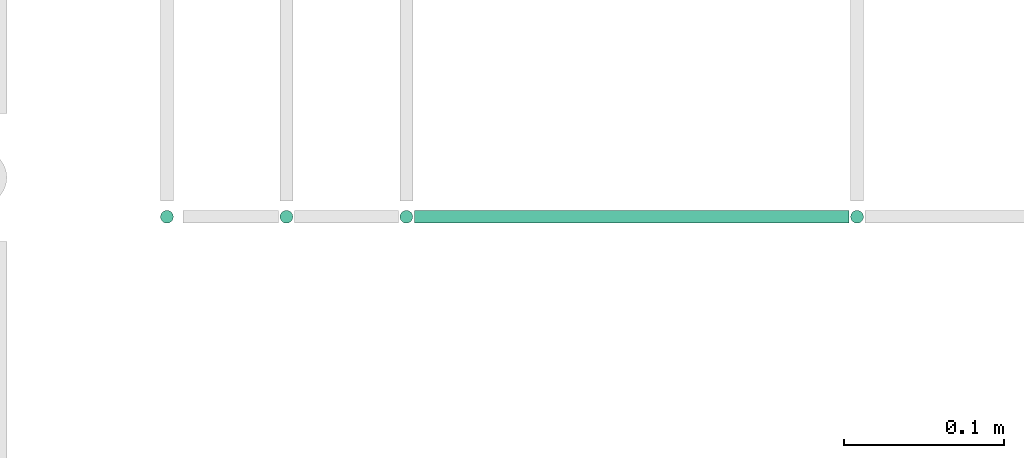
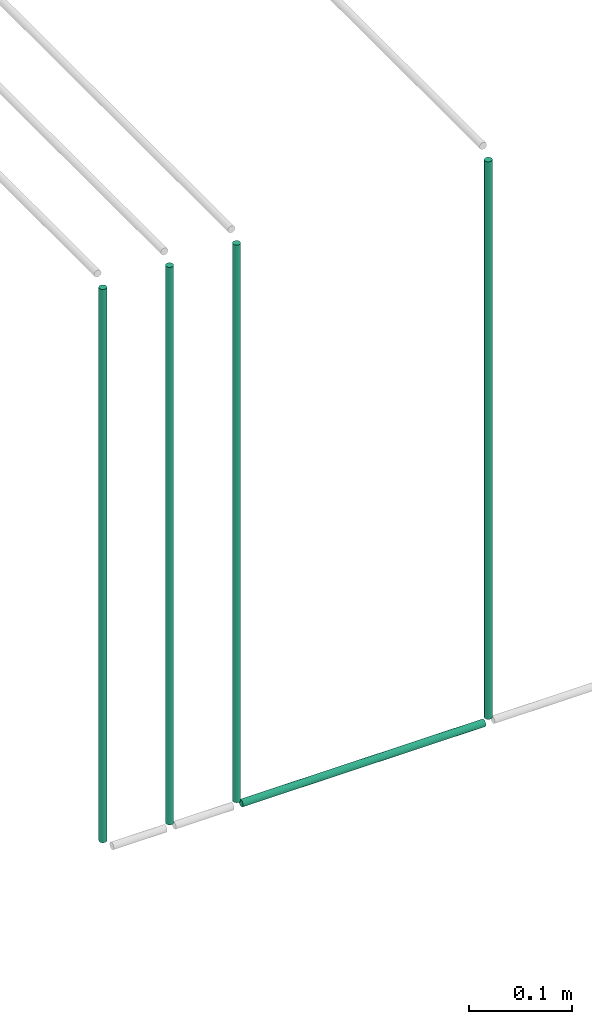
# One storey, part 243 of 331: 5 flow segments.
"""IFC2X3 building model written with IfcOpenShell, lengths in millimetres."""

from ifc_helpers import new_model, entity, si_unit, converted_unit, derived_unit, direction, frame, origin, origin_2d_with_axis, place, context, subcontext, project, spatial, circle, extrude, type_object, element, save


model = new_model("IFC2X3")

# Units and contexts
model_context = context("Model", 3, precision=0.01, world=origin(), true_north=direction((6.12303176911189e-17, 1.0)))
body_context = subcontext(model_context, "Body", "Model", "MODEL_VIEW")
ifc_project = project(units=[si_unit("LENGTHUNIT", "METRE", prefix="MILLI"), si_unit("AREAUNIT", "SQUARE_METRE"), si_unit("VOLUMEUNIT", "CUBIC_METRE"), converted_unit("PLANEANGLEUNIT", "DEGREE", entity("IfcRatioMeasure", 0.0174532925199433), si_unit("PLANEANGLEUNIT", "RADIAN"), dimensions=[0, 0, 0, 0, 0, 0, 0]), si_unit("MASSUNIT", "GRAM", prefix="KILO"), derived_unit("MASSDENSITYUNIT", [(si_unit("MASSUNIT", "GRAM", prefix="KILO"), 1), (si_unit("LENGTHUNIT", "METRE"), -3)]), derived_unit("MOMENTOFINERTIAUNIT", [(si_unit("LENGTHUNIT", "METRE"), 4)]), si_unit("TIMEUNIT", "SECOND"), si_unit("FREQUENCYUNIT", "HERTZ"), si_unit("THERMODYNAMICTEMPERATUREUNIT", "DEGREE_CELSIUS"), derived_unit("THERMALTRANSMITTANCEUNIT", [(si_unit("MASSUNIT", "GRAM", prefix="KILO"), 1), (si_unit("THERMODYNAMICTEMPERATUREUNIT", "KELVIN"), -1), (si_unit("TIMEUNIT", "SECOND"), -3)]), derived_unit("VOLUMETRICFLOWRATEUNIT", [(si_unit("LENGTHUNIT", "METRE"), 3), (si_unit("TIMEUNIT", "SECOND"), -1)]), derived_unit("MASSFLOWRATEUNIT", [(si_unit("MASSUNIT", "GRAM", prefix="KILO"), 1), (si_unit("TIMEUNIT", "SECOND"), -1)]), derived_unit("ROTATIONALFREQUENCYUNIT", [(si_unit("TIMEUNIT", "SECOND"), -1)]), si_unit("ELECTRICCURRENTUNIT", "AMPERE"), si_unit("ELECTRICVOLTAGEUNIT", "VOLT"), si_unit("POWERUNIT", "WATT"), si_unit("FORCEUNIT", "NEWTON", prefix="KILO"), si_unit("ILLUMINANCEUNIT", "LUX"), si_unit("LUMINOUSFLUXUNIT", "LUMEN"), si_unit("LUMINOUSINTENSITYUNIT", "CANDELA"), derived_unit("USERDEFINED", [(si_unit("MASSUNIT", "GRAM", prefix="KILO"), -1), (si_unit("LENGTHUNIT", "METRE"), -2), (si_unit("TIMEUNIT", "SECOND"), 3), (si_unit("LUMINOUSFLUXUNIT", "LUMEN"), 1)]), derived_unit("LINEARVELOCITYUNIT", [(si_unit("LENGTHUNIT", "METRE"), 1), (si_unit("TIMEUNIT", "SECOND"), -1)]), si_unit("PRESSUREUNIT", "PASCAL"), derived_unit("USERDEFINED", [(si_unit("LENGTHUNIT", "METRE"), -2), (si_unit("MASSUNIT", "GRAM", prefix="KILO"), 1), (si_unit("TIMEUNIT", "SECOND"), -2)]), derived_unit("LINEARFORCEUNIT", [(si_unit("MASSUNIT", "GRAM", prefix="KILO"), 1), (si_unit("LENGTHUNIT", "METRE"), 1), (si_unit("TIMEUNIT", "SECOND"), -2), (si_unit("LENGTHUNIT", "METRE"), -1)]), derived_unit("PLANARFORCEUNIT", [(si_unit("MASSUNIT", "GRAM", prefix="KILO"), 1), (si_unit("LENGTHUNIT", "METRE"), 1), (si_unit("TIMEUNIT", "SECOND"), -2), (si_unit("LENGTHUNIT", "METRE"), -2)])], contexts=[model_context])

# Site, building, storey
site_placement = place(None, frame((0.0, -0.00077364408347762, 0.0)))
site = spatial("IfcSite", under=ifc_project, at=site_placement, CompositionType="ELEMENT")
building_placement = place(site_placement, origin())
building = spatial("IfcBuilding", under=site, at=building_placement, CompositionType="ELEMENT")
storey_placement = place(building_placement, origin())
storey = spatial("IfcBuildingStorey", under=building, at=storey_placement, CompositionType="ELEMENT", Elevation=0.0)

# Flow segments
pipe_segment_type = type_object("IfcPipeSegmentType", PredefinedType="NOTDEFINED")
for number, where in (
    (1, (60309.3854351487, 16292.9115686369, 6680.0)),
    (2, (60027.5518978448, 16292.9115686369, 6680.0)),
):
    element("IfcFlowSegment", number, at=place(building_placement, frame(where)), inside=storey, type_object=pipe_segment_type, context=body_context, shape_type="SweptSolid", body=[
        extrude(circle(Radius=4.0, at=origin_2d_with_axis()), frame((5.59527223591499, 5.59527223591499, 0.0), z_axis=(0.0, 0.0, 1.0), x_axis=(-1.0, 0.0, 0.0)), (0.0, 0.0, 1.0), 660.000000000009),
    ])
flow_segment_1_placement = place(building_placement, frame((60038.1471700807, 16292.9115686369, 6669.40472776408)))
element("IfcFlowSegment", 3, at=flow_segment_1_placement, inside=storey, type_object=pipe_segment_type, context=body_context, shape_type="SweptSolid", body=[
    extrude(circle(Radius=4.0, at=origin_2d_with_axis()), frame((0.0, 5.59527223591499, 5.59527223591607), z_axis=(1.0, 0.0, 0.0), x_axis=(0.0, 1.0, 0.0)), (0.0, 0.0, 1.0), 271.833537303848),
])
flow_segment_2_placement = place(storey_placement, frame((59952.5518978448, 16292.9115686368, 6680.0)))
element("IfcFlowSegment", 4, at=flow_segment_2_placement, inside=storey, type_object=pipe_segment_type, context=body_context, shape_type="SweptSolid", body=[
    extrude(circle(Radius=4.0, at=origin_2d_with_axis()), frame((5.59527223591499, 5.59527223591499, 0.0), z_axis=(0.0, 0.0, 1.0), x_axis=(-1.0, 0.0, 0.0)), (0.0, 0.0, 1.0), 660.000000000002),
])
flow_segment_3_placement = place(storey_placement, frame((59877.8372954879, 16292.9115686369, 6685.0)))
element("IfcFlowSegment", 5, at=flow_segment_3_placement, inside=storey, type_object=pipe_segment_type, context=body_context, shape_type="SweptSolid", body=[
    extrude(circle(Radius=4.0, at=origin_2d_with_axis()), frame((5.59527223591499, 5.59527223591499, 0.0), z_axis=(0.0, 0.0, 1.0), x_axis=(-1.0, 0.0, 0.0)), (0.0, 0.0, 1.0), 655.000000000012),
])

save(model, "model.ifc")
